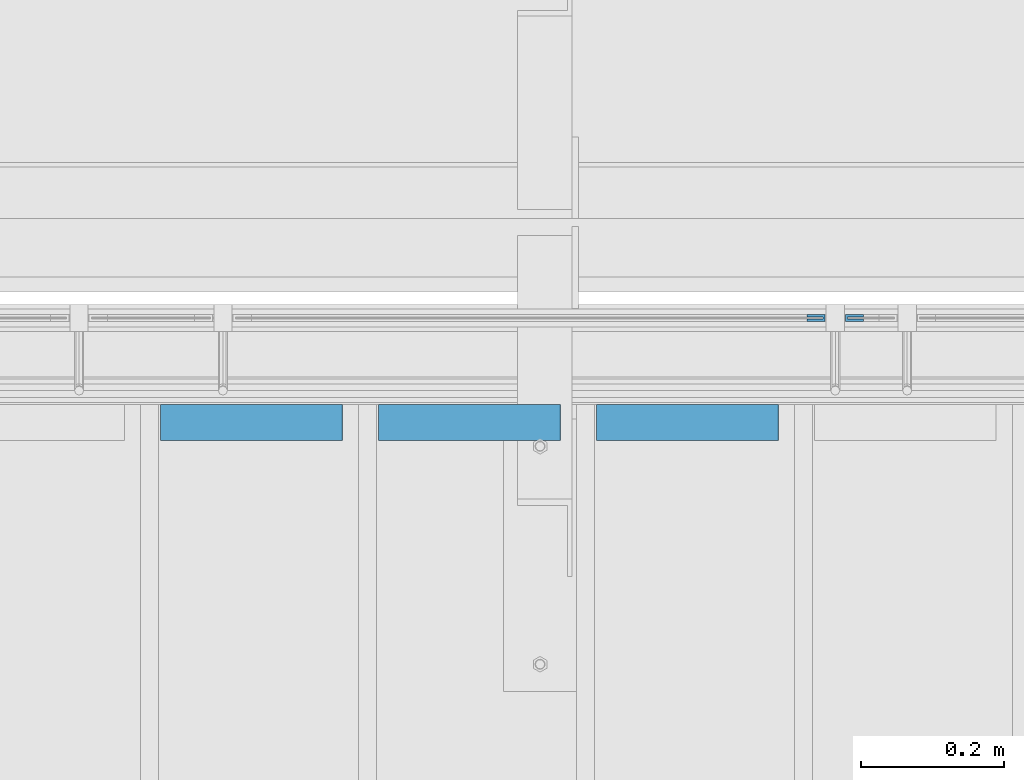
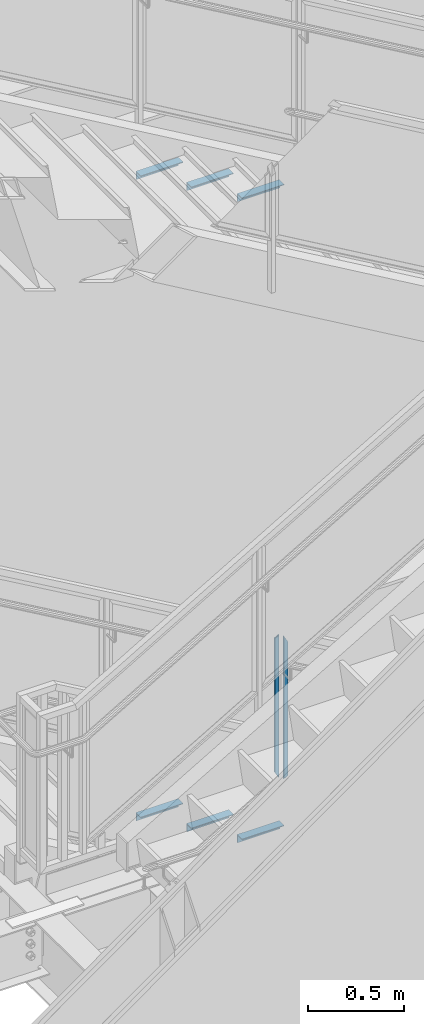
# One storey, part 943 of 1179: 8 beams, 3 elements without a shape of their own.
"""IFC2X3 building model written with IfcOpenShell, lengths in millimetres."""

from ifc_helpers import new_model, si_unit, frame, origin_with_axes, place, context, subcontext, project, spatial, faceted_brep, material, type_object, element, aggregate, save


model = new_model("IFC2X3")

# Units and contexts
model_context = context("Model", 3, precision=1e-05, world=origin_with_axes())
body_context = subcontext(model_context, "Body", "Model", "MODEL_VIEW")
ifc_project = project(units=[si_unit("LENGTHUNIT", "METRE", prefix="MILLI"), si_unit("AREAUNIT", "SQUARE_METRE"), si_unit("VOLUMEUNIT", "CUBIC_METRE"), si_unit("MASSUNIT", "GRAM", prefix="KILO"), si_unit("TIMEUNIT", "SECOND"), si_unit("PLANEANGLEUNIT", "RADIAN"), si_unit("SOLIDANGLEUNIT", "STERADIAN"), si_unit("THERMODYNAMICTEMPERATUREUNIT", "DEGREE_CELSIUS"), si_unit("LUMINOUSINTENSITYUNIT", "LUMEN")], contexts=[model_context])

# Site, building, storey
site_placement = place(None, origin_with_axes())
site = spatial("IfcSite", under=ifc_project, at=site_placement, CompositionType="ELEMENT")
building_placement = place(site_placement, origin_with_axes())
building = spatial("IfcBuilding", under=site, at=building_placement, Name="Undefined", CompositionType="ELEMENT")
storey_placement = place(building_placement, origin_with_axes())
storey = spatial("IfcBuildingStorey", under=building, at=storey_placement, Name="Undefined", CompositionType="ELEMENT", Elevation=0.0)

# Assembly, beams
assembly_1_placement = place(storey_placement, origin_with_axes())
assembly_1 = element("IfcElementAssembly", 1, at=assembly_1_placement, inside=storey, Name="GUARDRAIL", AssemblyPlace="NOTDEFINED", PredefinedType="RIGID_FRAME")
ifc_material_1 = material(Name="STEEL/BUY-OUT")
beam_type_1 = type_object("IfcBeamType", PredefinedType="NOTDEFINED")
beam_1_placement = place(assembly_1_placement, frame((21626.5124246046, 41062.2751647691, 3578.53056841568), z_axis=(0.0, 0.0, -1.0), x_axis=(1.0, 0.0, 0.0)))
beam_1 = element("IfcBeam", 2, at=beam_1_placement, type_object=beam_type_1, material=ifc_material_1, Name="U-EDGE", context=body_context, shape_type="Brep", body=[
    faceted_brep([(0.0, 1.58750000000146, 410.762302941614), (25.400000000016, 1.58750000000146, 454.819), (25.400000000016, 1.58750000000146, -454.819), (0.0, 1.58750000000146, -440.175144311391), (0.0, -1.58750000000146, 410.762302941614), (0.0, -1.58750000000146, -440.175144311391), (22.2250000000131, -1.58750000000146, 449.311912867583), (22.2250000000131, -1.58750000000146, -452.988518038564), (22.2250000000131, -4.76249999999709, 449.311912867583), (22.2250000000131, -4.76249999999709, -452.988518038564), (2.91038304567337e-11, -4.76249999999709, 410.762302941664), (2.91038304567337e-11, -4.76249999999709, -440.175144311408), (2.91038304567337e-11, -7.9375, 410.762302941664), (2.91038304567337e-11, -7.9375, -440.175144311408), (25.400000000016, -7.9375, 454.819), (25.400000000016, -7.9375, -454.819)], [[[0, 1, 2, 3]], [[4, 0, 3, 5]], [[6, 4, 5, 7]], [[8, 6, 7, 9]], [[10, 8, 9, 11]], [[12, 10, 11, 13]], [[14, 12, 13, 15]], [[11, 9, 7, 5, 3, 2, 15, 13]], [[1, 14, 15, 2]], [[0, 4, 6, 8, 10, 12, 14, 1]]]),
])
beam_2_placement = place(assembly_1_placement, frame((21705.5830340909, 41062.2751647691, 3562.16208185029), z_axis=(0.0, 0.0, -1.0), x_axis=(-1.0, 0.0, 0.0)))
beam_2 = element("IfcBeam", 3, at=beam_2_placement, type_object=beam_type_1, material=ifc_material_1, Name="U-EDGE", context=body_context, shape_type="Brep", body=[
    faceted_brep([(2.91038304567337e-11, 7.9375, 440.175302877862), (25.3999999999687, 7.9375, 454.819), (25.400000000016, 7.9375, -454.819), (2.91038304567337e-11, 7.9375, -410.76229705665), (2.91038304567337e-11, 4.76249999999709, 440.175302877862), (2.91038304567337e-11, 4.76249999999709, -410.76229705665), (22.2250000000131, 4.76249999999709, 452.988538277322), (22.2250000000131, 4.76249999999709, -449.311912132071), (22.2250000000131, 1.58750000000146, 452.988538277322), (22.2250000000131, 1.58750000000146, -449.311912132071), (0.0, 1.58750000000146, 440.175302877845), (0.0, 1.58750000000146, -410.7622970566), (0.0, -1.58750000000146, 440.175302877845), (0.0, -1.58750000000146, -410.7622970566), (25.3999999999687, -1.58750000000146, 454.819), (25.400000000016, -1.58750000000146, -454.819)], [[[0, 1, 2, 3]], [[4, 0, 3, 5]], [[6, 4, 5, 7]], [[8, 6, 7, 9]], [[10, 8, 9, 11]], [[12, 10, 11, 13]], [[14, 12, 13, 15]], [[11, 9, 7, 5, 3, 2, 15, 13]], [[1, 14, 15, 2]], [[0, 4, 6, 8, 10, 12, 14, 1]]]),
])
aggregate(assembly_1, [beam_1, beam_2])

assembly_2_placement = place(storey_placement, origin_with_axes())
assembly_2 = element("IfcElementAssembly", 4, at=assembly_2_placement, inside=storey, Name="STAIR", AssemblyPlace="NOTDEFINED", PredefinedType="RIGID_FRAME")
ifc_material_2 = material(Name="STEEL/A36")
beam_type_2 = type_object("IfcBeamType", Name="L2X2X3/16", PredefinedType="NOTDEFINED")
beam_3_placement = place(assembly_2_placement, frame((20722.8321735152, 40919.400000127, 3274.28488298653), z_axis=(0.0, -1.0, 0.0), x_axis=(1.0, 0.0, 0.0)))
beam_3 = element("IfcBeam", 5, at=beam_3_placement, type_object=beam_type_2, material=ifc_material_2, Name="ANGLE", ObjectType="L2X2X3/16", context=body_context, shape_type="Brep", body=[
    faceted_brep([(0.0, 25.3999999999996, -25.4000000000015), (0.0, 25.3999999999996, 25.4000000000015), (254.0, 25.3999999999996, 25.4000000000001), (254.0, 25.3999999999996, -25.4000000000001), (0.0, 20.6374999999998, 25.4000000000015), (254.0, 20.6374999999998, 25.4000000000001), (0.0, 20.6374999999998, -20.6374999999971), (254.0, 20.6374999999998, -20.6374999999998), (0.0, -25.3999999999996, -20.6374999999971), (254.0, -25.3999999999996, -20.6374999999998), (0.0, -25.3999999999996, -25.4000000000015), (254.0, -25.3999999999996, -25.4000000000001)], [[[0, 1, 2, 3]], [[1, 4, 5, 2]], [[4, 6, 7, 5]], [[6, 8, 9, 7]], [[8, 10, 11, 9]], [[10, 0, 3, 11]], [[5, 7, 9, 11, 3, 2]], [[10, 8, 6, 4, 1, 0]]]),
])
beam_4_placement = place(assembly_2_placement, frame((21027.6321735078, 40919.4000001248, 3097.80779970282), z_axis=(0.0, -1.0, 0.0), x_axis=(1.0, 0.0, 0.0)))
beam_4 = element("IfcBeam", 6, at=beam_4_placement, type_object=beam_type_2, material=ifc_material_2, Name="ANGLE", ObjectType="L2X2X3/16", context=body_context, shape_type="Brep", body=[
    faceted_brep([(0.0, 25.3999999999996, -25.4000000000015), (0.0, 25.3999999999996, 25.4000000000015), (254.0, 25.3999999999996, 25.4000000000001), (254.0, 25.3999999999996, -25.4000000000001), (0.0, 20.6374999999998, 25.4000000000015), (254.0, 20.6374999999998, 25.4000000000001), (0.0, 20.6374999999998, -20.6374999999971), (254.0, 20.6374999999998, -20.6374999999998), (0.0, -25.3999999999996, -20.6374999999971), (254.0, -25.3999999999996, -20.6374999999998), (0.0, -25.3999999999996, -25.4000000000015), (254.0, -25.3999999999996, -25.4000000000001)], [[[0, 1, 2, 3]], [[1, 4, 5, 2]], [[4, 6, 7, 5]], [[6, 8, 9, 7]], [[8, 10, 11, 9]], [[10, 0, 3, 11]], [[5, 7, 9, 11, 3, 2]], [[10, 8, 6, 4, 1, 0]]]),
])
beam_5_placement = place(assembly_2_placement, frame((21332.4321735004, 40919.4000001226, 2921.33071641911), z_axis=(0.0, -1.0, 0.0), x_axis=(1.0, 0.0, 0.0)))
beam_5 = element("IfcBeam", 7, at=beam_5_placement, type_object=beam_type_2, material=ifc_material_2, Name="ANGLE", ObjectType="L2X2X3/16", context=body_context, shape_type="Brep", body=[
    faceted_brep([(0.0, 25.3999999999996, -25.4000000000015), (0.0, 25.3999999999996, 25.4000000000015), (254.0, 25.3999999999996, 25.4000000000001), (254.0, 25.3999999999996, -25.4000000000001), (0.0, 20.6374999999998, 25.4000000000015), (254.0, 20.6374999999998, 25.4000000000001), (0.0, 20.6374999999998, -20.6374999999971), (254.0, 20.6374999999998, -20.6374999999998), (0.0, -25.3999999999996, -20.6374999999971), (254.0, -25.3999999999996, -20.6374999999998), (0.0, -25.3999999999996, -25.4000000000015), (254.0, -25.3999999999996, -25.4000000000001)], [[[0, 1, 2, 3]], [[1, 4, 5, 2]], [[4, 6, 7, 5]], [[6, 8, 9, 7]], [[8, 10, 11, 9]], [[10, 0, 3, 11]], [[5, 7, 9, 11, 3, 2]], [[10, 8, 6, 4, 1, 0]]]),
])
aggregate(assembly_2, [beam_3, beam_4, beam_5])

assembly_3_placement = place(storey_placement, origin_with_axes())
assembly_3 = element("IfcElementAssembly", 8, at=assembly_3_placement, inside=storey, Name="STAIR", AssemblyPlace="NOTDEFINED", PredefinedType="RIGID_FRAME")
beam_6_placement = place(assembly_3_placement, frame((20722.8869685408, 40919.3999999982, 7357.07030000811), z_axis=(0.0, -1.0, 0.0), x_axis=(1.0, 0.0, 0.0)))
beam_6 = element("IfcBeam", 9, at=beam_6_placement, type_object=beam_type_2, material=ifc_material_2, Name="ANGLE", ObjectType="L2X2X3/16", context=body_context, shape_type="Brep", body=[
    faceted_brep([(0.0, 25.3999999999996, -25.4000000000015), (0.0, 25.3999999999996, 25.4000000000015), (254.0, 25.3999999999996, 25.4000000000001), (254.0, 25.3999999999996, -25.4000000000001), (0.0, 20.6374999999998, 25.4000000000015), (254.0, 20.6374999999998, 25.4000000000001), (0.0, 20.6374999999998, -20.6374999999971), (254.0, 20.6374999999998, -20.6374999999998), (0.0, -25.3999999999996, -20.6374999999971), (254.0, -25.3999999999996, -20.6374999999998), (0.0, -25.3999999999996, -25.4000000000015), (254.0, -25.3999999999996, -25.4000000000001)], [[[0, 1, 2, 3]], [[1, 4, 5, 2]], [[4, 6, 7, 5]], [[6, 8, 9, 7]], [[8, 10, 11, 9]], [[10, 0, 3, 11]], [[5, 7, 9, 11, 3, 2]], [[10, 8, 6, 4, 1, 0]]]),
])
beam_7_placement = place(assembly_3_placement, frame((21027.6869682887, 40919.3999999982, 7179.27030000811), z_axis=(0.0, -1.0, 0.0), x_axis=(1.0, 0.0, 0.0)))
beam_7 = element("IfcBeam", 10, at=beam_7_placement, type_object=beam_type_2, material=ifc_material_2, Name="ANGLE", ObjectType="L2X2X3/16", context=body_context, shape_type="Brep", body=[
    faceted_brep([(0.0, 25.3999999999996, -25.4000000000015), (0.0, 25.3999999999996, 25.4000000000015), (254.0, 25.3999999999996, 25.4000000000001), (254.0, 25.3999999999996, -25.4000000000001), (0.0, 20.6374999999998, 25.4000000000015), (254.0, 20.6374999999998, 25.4000000000001), (0.0, 20.6374999999998, -20.6374999999971), (254.0, 20.6374999999998, -20.6374999999998), (0.0, -25.3999999999996, -20.6374999999971), (254.0, -25.3999999999996, -20.6374999999998), (0.0, -25.3999999999996, -25.4000000000015), (254.0, -25.3999999999996, -25.4000000000001)], [[[0, 1, 2, 3]], [[1, 4, 5, 2]], [[4, 6, 7, 5]], [[6, 8, 9, 7]], [[8, 10, 11, 9]], [[10, 0, 3, 11]], [[5, 7, 9, 11, 3, 2]], [[10, 8, 6, 4, 1, 0]]]),
])
beam_8_placement = place(assembly_3_placement, frame((21332.4869680367, 40919.3999999982, 7001.47030000811), z_axis=(0.0, -1.0, 0.0), x_axis=(1.0, 0.0, 0.0)))
beam_8 = element("IfcBeam", 11, at=beam_8_placement, type_object=beam_type_2, material=ifc_material_2, Name="ANGLE", ObjectType="L2X2X3/16", context=body_context, shape_type="Brep", body=[
    faceted_brep([(0.0, 25.3999999999996, -25.4000000000015), (0.0, 25.3999999999996, 25.4000000000015), (254.0, 25.3999999999996, 25.4000000000001), (254.0, 25.3999999999996, -25.4000000000001), (0.0, 20.6374999999998, 25.4000000000015), (254.0, 20.6374999999998, 25.4000000000001), (0.0, 20.6374999999998, -20.6374999999971), (254.0, 20.6374999999998, -20.6374999999998), (0.0, -25.3999999999996, -20.6374999999971), (254.0, -25.3999999999996, -20.6374999999998), (0.0, -25.3999999999996, -25.4000000000015), (254.0, -25.3999999999996, -25.4000000000001)], [[[0, 1, 2, 3]], [[1, 4, 5, 2]], [[4, 6, 7, 5]], [[6, 8, 9, 7]], [[8, 10, 11, 9]], [[10, 0, 3, 11]], [[5, 7, 9, 11, 3, 2]], [[10, 8, 6, 4, 1, 0]]]),
])
aggregate(assembly_3, [beam_6, beam_7, beam_8])

save(model, "model.ifc")
